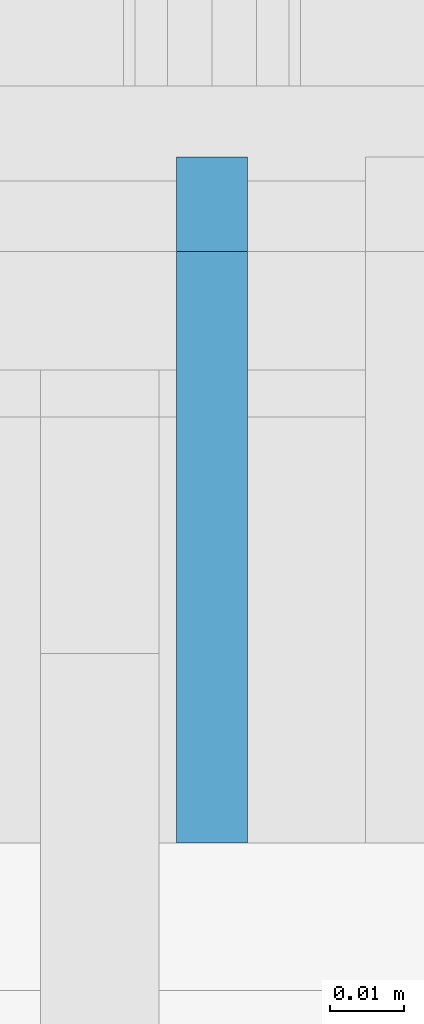
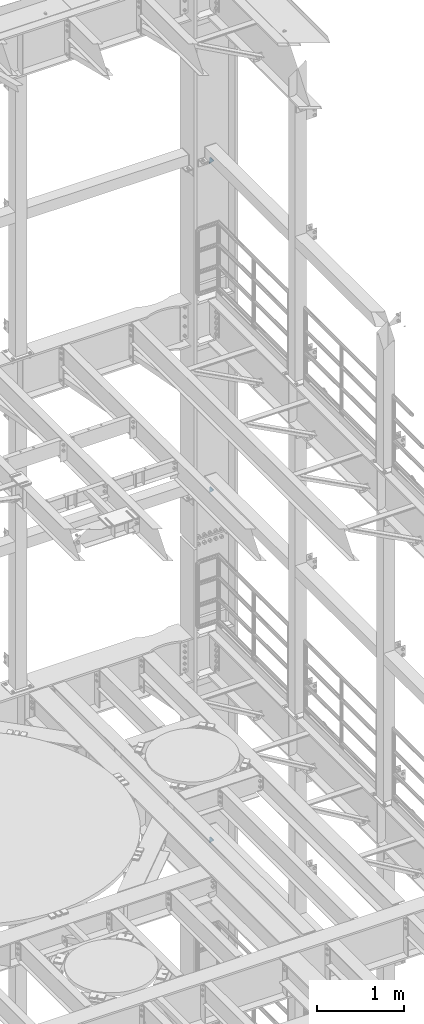
# One storey, part 1827 of 1876: 3 plates, 2 elements without a shape of their own.
"""IFC2X3 building model written with IfcOpenShell, lengths in millimetres."""

from ifc_helpers import new_model, si_unit, frame, origin_with_axes, place, context, subcontext, project, spatial, faceted_brep, material, type_object, element, aggregate, save


model = new_model("IFC2X3")

# Units and contexts
model_context = context("Model", 3, precision=1e-05, world=origin_with_axes())
body_context = subcontext(model_context, "Body", "Model", "MODEL_VIEW")
ifc_project = project(units=[si_unit("LENGTHUNIT", "METRE", prefix="MILLI"), si_unit("AREAUNIT", "SQUARE_METRE"), si_unit("VOLUMEUNIT", "CUBIC_METRE"), si_unit("MASSUNIT", "GRAM", prefix="KILO"), si_unit("TIMEUNIT", "SECOND"), si_unit("PLANEANGLEUNIT", "RADIAN"), si_unit("SOLIDANGLEUNIT", "STERADIAN"), si_unit("THERMODYNAMICTEMPERATUREUNIT", "DEGREE_CELSIUS"), si_unit("LUMINOUSINTENSITYUNIT", "LUMEN")], contexts=[model_context])

# Site, building, storey
site_placement = place(None, origin_with_axes())
site = spatial("IfcSite", under=ifc_project, at=site_placement, CompositionType="ELEMENT")
building_placement = place(site_placement, origin_with_axes())
building = spatial("IfcBuilding", under=site, at=building_placement, Name="Undefined", CompositionType="ELEMENT")
storey_placement = place(building_placement, origin_with_axes())
storey = spatial("IfcBuildingStorey", under=building, at=storey_placement, Name="Undefined", CompositionType="ELEMENT", Elevation=0.0)

# Assembly, plates
assembly_1_placement = place(storey_placement, origin_with_axes())
assembly_1 = element("IfcElementAssembly", 1, at=assembly_1_placement, inside=storey, Name="COLUMN", AssemblyPlace="NOTDEFINED", PredefinedType="RIGID_FRAME")
ifc_material = material(Name="STEEL/A36")
plate_type = type_object("IfcPlateType", PredefinedType="NOTDEFINED")
plate_1_placement = place(assembly_1_placement, frame((7620.0, 13602.4937494032, 19862.8), z_axis=(0.0, 0.707106781186548, 0.707106781186548), x_axis=(0.0, 0.707106781186548, -0.707106781186548)))
plate_1 = element("IfcPlate", 2, at=plate_1_placement, type_object=plate_type, material=ifc_material, Name="PLATE", context=body_context, shape_type="Brep", body=[
    faceted_brep([(0.0, -4.76249999999982, 0.0), (56.1266013136901, -4.76249999997708, 56.1266013135391), (56.1266013136883, 4.76250000002256, 56.1266013135428), (0.0, 4.76249999999982, 0.0), (74.0871132860975, -4.7624999999698, 56.1266013135246), (74.0871132860993, 4.76250000002983, 56.1266013135282), (130.213714599717, -4.76249999994707, -1.30967237055302e-10), (130.213714599715, 4.76250000005257, -1.23691279441118e-10)], [[[0, 1, 2, 3]], [[1, 4, 5, 2]], [[4, 6, 7, 5]], [[6, 0, 3, 7]], [[5, 7, 3, 2]], [[6, 4, 1, 0]]]),
])
plate_2_placement = place(assembly_1_placement, frame((7620.0, 13602.4937494032, 15240.0), z_axis=(0.0, 0.707106781186548, 0.707106781186548), x_axis=(0.0, 0.707106781186548, -0.707106781186548)))
plate_2 = element("IfcPlate", 3, at=plate_2_placement, type_object=plate_type, material=ifc_material, Name="PLATE", context=body_context, shape_type="Brep", body=[
    faceted_brep([(0.0, -4.76249999999982, 0.0), (56.1266013136901, -4.76249999997708, 56.1266013135391), (56.1266013136883, 4.76250000002256, 56.1266013135428), (0.0, 4.76249999999982, 0.0), (74.0871132860975, -4.7624999999698, 56.1266013135246), (74.0871132860993, 4.76250000002983, 56.1266013135282), (130.213714599717, -4.76249999994707, -1.30967237055302e-10), (130.213714599715, 4.76250000005257, -1.23691279441118e-10)], [[[0, 1, 2, 3]], [[1, 4, 5, 2]], [[4, 6, 7, 5]], [[6, 0, 3, 7]], [[5, 7, 3, 2]], [[6, 4, 1, 0]]]),
])
aggregate(assembly_1, [plate_1, plate_2])

# Assembly, plate
assembly_2_placement = place(storey_placement, origin_with_axes())
assembly_2 = element("IfcElementAssembly", 4, at=assembly_2_placement, inside=storey, Name="COLUMN", AssemblyPlace="NOTDEFINED", PredefinedType="RIGID_FRAME")
plate_3_placement = place(assembly_2_placement, frame((7620.0, 13602.4937494032, 10325.1), z_axis=(0.0, 0.707106781186548, 0.707106781186548), x_axis=(0.0, 0.707106781186548, -0.707106781186548)))
plate_3 = element("IfcPlate", 5, at=plate_3_placement, type_object=plate_type, material=ifc_material, Name="PLATE", context=body_context, shape_type="Brep", body=[
    faceted_brep([(0.0, -4.76249999999982, 0.0), (56.1266013136901, -4.76249999997708, 56.1266013135391), (56.1266013136883, 4.76250000002256, 56.1266013135428), (0.0, 4.76249999999982, 0.0), (74.0871132860975, -4.7624999999698, 56.1266013135246), (74.0871132860993, 4.76250000002983, 56.1266013135282), (130.213714599717, -4.76249999994707, -1.30967237055302e-10), (130.213714599715, 4.76250000005257, -1.23691279441118e-10)], [[[0, 1, 2, 3]], [[1, 4, 5, 2]], [[4, 6, 7, 5]], [[6, 0, 3, 7]], [[5, 7, 3, 2]], [[6, 4, 1, 0]]]),
])
aggregate(assembly_2, [plate_3])

save(model, "model.ifc")
